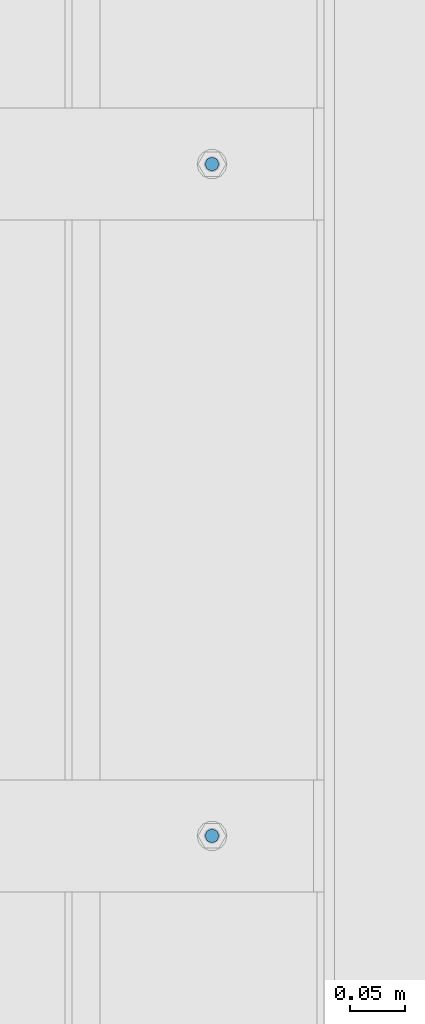
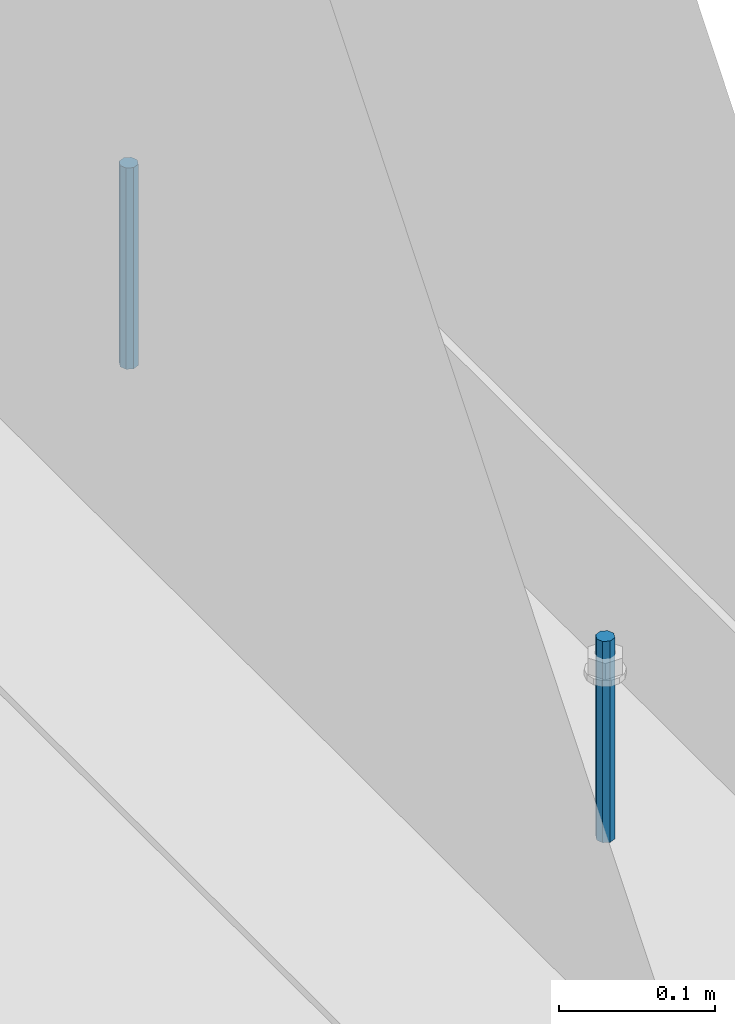
# One storey, part 413 of 1179: 2 columns, 1 element without a shape of its own.
"""IFC2X3 building model written with IfcOpenShell, lengths in millimetres."""

from ifc_helpers import new_model, si_unit, frame, origin_with_axes, place, context, subcontext, project, spatial, faceted_brep, material, type_object, element, aggregate, save


model = new_model("IFC2X3")

# Units and contexts
model_context = context("Model", 3, precision=1e-05, world=origin_with_axes())
body_context = subcontext(model_context, "Body", "Model", "MODEL_VIEW")
ifc_project = project(units=[si_unit("LENGTHUNIT", "METRE", prefix="MILLI"), si_unit("AREAUNIT", "SQUARE_METRE"), si_unit("VOLUMEUNIT", "CUBIC_METRE"), si_unit("MASSUNIT", "GRAM", prefix="KILO"), si_unit("TIMEUNIT", "SECOND"), si_unit("PLANEANGLEUNIT", "RADIAN"), si_unit("SOLIDANGLEUNIT", "STERADIAN"), si_unit("THERMODYNAMICTEMPERATUREUNIT", "DEGREE_CELSIUS"), si_unit("LUMINOUSINTENSITYUNIT", "LUMEN")], contexts=[model_context])

# Site, building, storey
site_placement = place(None, origin_with_axes())
site = spatial("IfcSite", under=ifc_project, at=site_placement, CompositionType="ELEMENT")
building_placement = place(site_placement, origin_with_axes())
building = spatial("IfcBuilding", under=site, at=building_placement, Name="Undefined", CompositionType="ELEMENT")
storey_placement = place(building_placement, origin_with_axes())
storey = spatial("IfcBuildingStorey", under=building, at=storey_placement, Name="Undefined", CompositionType="ELEMENT", Elevation=0.0)

# Assembly, columns
assembly_placement = place(storey_placement, origin_with_axes())
assembly = element("IfcElementAssembly", 1, at=assembly_placement, inside=storey, Name="BEAM", AssemblyPlace="NOTDEFINED", PredefinedType="RIGID_FRAME")
ifc_material = material(Name="STEEL/A307")
column_type = type_object("IfcColumnType", PredefinedType="NOTDEFINED")
column_1_placement = place(assembly_placement, frame((24638.0, 15354.3, 4108.45), z_axis=(0.0, 1.0, 0.0), x_axis=(0.0, 0.0, 1.0)))
column_1 = element("IfcColumn", 2, at=column_1_placement, type_object=column_type, material=ifc_material, Name="THREADED ROD", context=body_context, shape_type="Brep", body=[
    faceted_brep([(0.0, -6.34999999999854, 0.0), (0.0, -4.49012806053361, -4.49012806053452), (157.162499999999, -4.49012806053361, -4.49012806053361), (157.162499999999, -6.34999999999854, 0.0), (0.0, 0.0, -6.34999999999991), (157.162499999999, 0.0, -6.34999999999854), (0.0, 4.49012806053361, -4.49012806053452), (157.162499999999, 4.49012806053361, -4.49012806053361), (0.0, 6.34999999999854, 0.0), (157.162499999999, 6.34999999999854, 0.0), (0.0, 4.49012806053361, 4.49012806053452), (157.162499999999, 4.49012806053361, 4.49012806053361), (0.0, 0.0, 6.34999999999991), (157.162499999999, 0.0, 6.34999999999854), (0.0, -4.49012806053361, 4.49012806053452), (157.162499999999, -4.49012806053361, 4.49012806053361)], [[[0, 1, 2, 3]], [[1, 4, 5, 2]], [[4, 6, 7, 5]], [[6, 8, 9, 7]], [[8, 10, 11, 9]], [[10, 12, 13, 11]], [[12, 14, 15, 13]], [[14, 0, 3, 15]], [[5, 7, 9, 11, 13, 15, 3, 2]], [[14, 12, 10, 8, 6, 4, 1, 0]]]),
])
column_2_placement = place(assembly_placement, frame((24638.0, 14744.7, 4108.45), z_axis=(0.0, 1.0, 0.0), x_axis=(0.0, 0.0, 1.0)))
column_2 = element("IfcColumn", 3, at=column_2_placement, type_object=column_type, material=ifc_material, Name="THREADED ROD", context=body_context, shape_type="Brep", body=[
    faceted_brep([(0.0, -6.34999999999854, 0.0), (0.0, -4.49012806053361, -4.49012806053452), (157.162499999999, -4.49012806053361, -4.49012806053361), (157.162499999999, -6.34999999999854, 0.0), (0.0, 0.0, -6.34999999999991), (157.162499999999, 0.0, -6.34999999999854), (0.0, 4.49012806053361, -4.49012806053452), (157.162499999999, 4.49012806053361, -4.49012806053361), (0.0, 6.34999999999854, 0.0), (157.162499999999, 6.34999999999854, 0.0), (0.0, 4.49012806053361, 4.49012806053452), (157.162499999999, 4.49012806053361, 4.49012806053361), (0.0, 0.0, 6.34999999999991), (157.162499999999, 0.0, 6.34999999999854), (0.0, -4.49012806053361, 4.49012806053452), (157.162499999999, -4.49012806053361, 4.49012806053361)], [[[0, 1, 2, 3]], [[1, 4, 5, 2]], [[4, 6, 7, 5]], [[6, 8, 9, 7]], [[8, 10, 11, 9]], [[10, 12, 13, 11]], [[12, 14, 15, 13]], [[14, 0, 3, 15]], [[5, 7, 9, 11, 13, 15, 3, 2]], [[14, 12, 10, 8, 6, 4, 1, 0]]]),
])
aggregate(assembly, [column_1, column_2])

save(model, "model.ifc")
